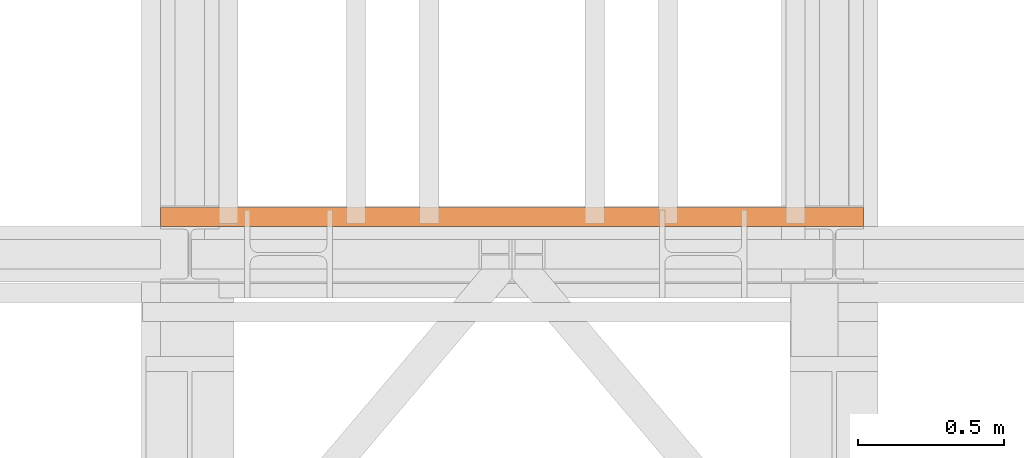
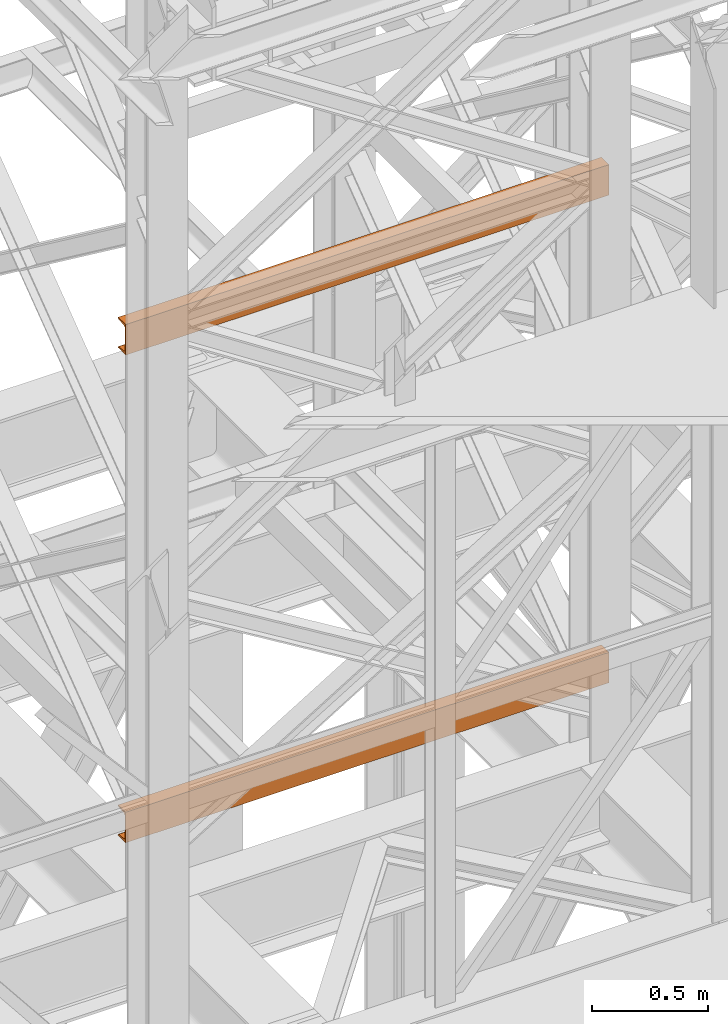
# One storey, part 149 of 208: 2 proxies.
"""IFC2X3 building model written with IfcOpenShell, lengths in millimetres."""

from ifc_helpers import new_model, entity, si_unit, converted_unit, frame, origin, origin_with_axes, place, context, subcontext, project, spatial, faceted_brep, element, save


model = new_model("IFC2X3")

# Units and contexts
model_context = context("Model", 3, precision=1e-05, world=origin())
plan_context = context("Plan", 3, precision=1e-05, world=origin())
body_context = subcontext(model_context, "Body", "Model", "MODEL_VIEW")
ifc_project = project(units=[si_unit("LENGTHUNIT", "METRE", prefix="MILLI"), converted_unit("PLANEANGLEUNIT", "DEGREE", entity("IfcPlaneAngleMeasure", 0.0174532925199433), si_unit("PLANEANGLEUNIT", "RADIAN"), dimensions=[0, 0, 0, 0, 0, 0, 0]), si_unit("AREAUNIT", "SQUARE_METRE"), si_unit("VOLUMEUNIT", "CUBIC_METRE")], contexts=[model_context, plan_context])

# Building, storey
building_placement = place(None, origin())
building = spatial("IfcBuilding", under=ifc_project, at=building_placement, CompositionType="COMPLEX")
storey_placement = place(building_placement, origin_with_axes())
storey = spatial("IfcBuildingStorey", under=building, at=storey_placement, Name="Geschoss", CompositionType="ELEMENT")

# Proxies
proxy_1_placement = place(storey_placement, frame((3193.302372304859, -15867.5743840594, 5524.960005364417), z_axis=(0.0, 0.0, 1.0), x_axis=(1.0, 0.0, 0.0)))
element("IfcBuildingElementProxy", 1, at=proxy_1_placement, inside=storey, context=body_context, shape_type="Brep", body=[
    faceted_brep([(2399.962597713924, 0.01853275732537441, 160.0100000000002), (0.009999999999308784, 0.00999999999839929, 160.0100000000002), (0.009999999999308784, 65.0099999999984, 160.0100000000002), (2399.962597713924, 65.01853275732537, 160.0100000000002), (2399.962597713924, 65.01853275732537, 160.0100000000002), (0.009999999999308784, 65.0099999999984, 160.0100000000002), (0.009999999999308784, 65.0099999999984, 156.8875719297539), (2399.962597713924, 65.01853275732537, 156.8875719297539), (2399.962597713924, 65.01853275732537, 156.8875719297539), (0.009999999999308784, 65.0099999999984, 156.8875719297539), (0.009999999999308784, 64.76726342282564, 155.2717110918293), (2399.962597713924, 64.77579618015261, 155.2717110918293), (2399.962597713924, 64.77579618015261, 155.2717110918293), (0.009999999999308784, 64.76726342282564, 155.2717110918293), (0.009999999999308784, 64.06053228585733, 153.7984655565542), (2399.962597713924, 64.06906504318067, 153.7984655565542), (2399.962597713924, 64.06906504318067, 153.7984655565542), (0.009999999999308784, 64.06053228585733, 153.7984655565542), (0.009999999999308784, 62.9521516384666, 152.5978732961266), (2399.962597713924, 62.96068439579358, 152.5978732961266), (2399.962597713924, 62.96068439579358, 152.5978732961266), (0.009999999999308784, 62.9521516384666, 152.5978732961266), (0.009999999999308784, 61.5399564114814, 151.7759086082897), (2399.962597713924, 61.54848916880837, 151.7759086082897), (2399.962597713924, 61.54848916880837, 151.7759086082897), (0.009999999999308784, 61.5399564114814, 151.7759086082897), (0.009999999999308784, 59.94859872255256, 151.4050878978051), (2399.962597713924, 59.95713147987954, 151.4050878978051), (2399.962597713924, 59.95713147987954, 151.4050878978051), (0.009999999999308784, 59.94859872255256, 151.4050878978051), (0.009999999999308784, 17.17267516602806, 147.9830140132835), (2399.962597713924, 17.18120792335503, 147.9830140132835), (2399.962597713924, 17.18120792335503, 147.9830140132835), (0.009999999999308784, 17.17267516602806, 147.9830140132835), (0.009999999999308784, 14.20840820800731, 147.318026761528), (2399.962597713924, 14.21694096533429, 147.318026761528), (2399.962597713924, 14.21694096533429, 147.318026761528), (0.009999999999308784, 14.20840820800731, 147.318026761528), (0.009999999999308784, 11.43861959928836, 145.7058782528511), (2399.962597713924, 11.4471523566117, 145.7058782528511), (2399.962597713924, 11.4471523566117, 145.7058782528511), (0.009999999999308784, 11.43861959928836, 145.7058782528511), (0.009999999999308784, 9.322620181545062, 143.4138384829421), (2399.962597713924, 9.331152938872037, 143.4138384829421), (2399.962597713924, 9.331152938872037, 143.4138384829421), (0.009999999999308784, 9.322620181545062, 143.4138384829421), (0.009999999999308784, 7.973406192784751, 140.6012788246917), (2399.962597713924, 7.981938950111726, 140.6012788246917), (2399.962597713924, 7.981938950111726, 140.6012788246917), (0.009999999999308784, 7.973406192784751, 140.6012788246917), (0.009999999999308784, 7.509999999998399, 137.5164535886543), (2399.962597713924, 7.518532757325374, 137.5164535886543), (2399.962597713924, 7.518532757325374, 137.5164535886543), (0.009999999999308784, 7.509999999998399, 137.5164535886543), (0.009999999999308784, 7.509999999998399, 22.503546411348), (2399.962597713924, 7.518532757325374, 22.503546411348), (2399.962597713924, 7.518532757325374, 22.503546411348), (0.009999999999308784, 7.509999999998399, 22.503546411348), (0.009999999999308784, 7.973406192784751, 19.41872117530875), (2399.962597713924, 7.981938950111726, 19.41872117530875), (2399.962597713924, 7.981938950111726, 19.41872117530875), (0.009999999999308784, 7.973406192784751, 19.41872117530875), (0.009999999999308784, 9.322620181545062, 16.60616151705835), (2399.962597713924, 9.331152938872037, 16.60616151705835), (2399.962597713924, 9.331152938872037, 16.60616151705835), (0.009999999999308784, 9.322620181545062, 16.60616151705835), (0.009999999999308784, 11.43861959928836, 14.31412174714933), (2399.962597713924, 11.4471523566117, 14.31412174714933), (2399.962597713924, 11.4471523566117, 14.31412174714933), (0.009999999999308784, 11.43861959928836, 14.31412174714933), (0.009999999999308784, 14.13462866898408, 12.74491643400688), (2399.962597713924, 14.14316142630742, 12.74491643400688), (2399.962597713924, 14.14316142630742, 12.74491643400688), (0.009999999999308784, 14.13462866898408, 12.74491643400688), (0.009999999999308784, 17.17267516602806, 12.03698598671872), (2399.962597713924, 17.18120792335503, 12.03698598671872), (2399.962597713924, 17.18120792335503, 12.03698598671872), (0.009999999999308784, 17.17267516602806, 12.03698598671872), (0.009999999999308784, 59.94859872255256, 8.614912102195376), (2399.962597713924, 59.95713147987954, 8.614912102195376), (2399.962597713924, 59.95713147987954, 8.614912102195376), (0.009999999999308784, 59.94859872255256, 8.614912102195376), (0.009999999999308784, 61.5399564114814, 8.244091391710754), (2399.962597713924, 61.54848916880837, 8.244091391710754), (2399.962597713924, 61.54848916880837, 8.244091391710754), (0.009999999999308784, 61.5399564114814, 8.244091391710754), (0.009999999999308784, 62.9521516384666, 7.422126703873801), (2399.962597713924, 62.96068439579358, 7.422126703873801), (2399.962597713924, 62.96068439579358, 7.422126703873801), (0.009999999999308784, 62.9521516384666, 7.422126703873801), (0.009999999999308784, 64.06053228585733, 6.221534443446217), (2399.962597713924, 64.06906504318067, 6.221534443446217), (2399.962597713924, 64.06906504318067, 6.221534443446217), (0.009999999999308784, 64.06053228585733, 6.221534443446217), (0.009999999999308784, 64.76726342282564, 4.748288908172981), (2399.962597713924, 64.77579618015261, 4.748288908172981), (2399.962597713924, 64.77579618015261, 4.748288908172981), (0.009999999999308784, 64.76726342282564, 4.748288908172981), (0.009999999999308784, 65.0099999999984, 0.01000000000021828), (2399.962597713924, 65.01853275732537, 0.01000000000021828), (2399.962597713924, 65.01853275732537, 0.01000000000021828), (0.009999999999308784, 65.0099999999984, 0.01000000000021828), (0.009999999999308784, 0.00999999999839929, 0.01000000000021828), (2399.962597713924, 0.01853275732537441, 0.01000000000021828), (2399.962597713924, 0.01853275732537441, 0.01000000000021828), (0.009999999999308784, 0.00999999999839929, 0.01000000000021828), (0.009999999999308784, 0.00999999999839929, 160.0100000000002), (2399.962597713924, 0.01853275732537441, 160.0100000000002), (2399.962597713924, 0.01853275732537441, 160.0100000000002), (2399.962597713924, 65.01853275732537, 160.0100000000002), (2399.962597713924, 65.01853275732537, 156.8875719297539), (2399.962597713924, 64.77579618015261, 155.2717110918293), (2399.962597713924, 64.06906504318067, 153.7984655565542), (2399.962597713924, 62.96068439579358, 152.5978732961266), (2399.962597713924, 61.54848916880837, 151.7759086082897), (2399.962597713924, 59.95713147987954, 151.4050878978051), (2399.962597713924, 17.18120792335503, 147.9830140132835), (2399.962597713924, 14.21694096533429, 147.318026761528), (2399.962597713924, 11.4471523566117, 145.7058782528511), (2399.962597713924, 9.331152938872037, 143.4138384829421), (2399.962597713924, 7.981938950111726, 140.6012788246917), (2399.962597713924, 7.518532757325374, 137.5164535886543), (2399.962597713924, 7.518532757325374, 22.503546411348), (2399.962597713924, 7.981938950111726, 19.41872117530875), (2399.962597713924, 9.331152938872037, 16.60616151705835), (2399.962597713924, 11.4471523566117, 14.31412174714933), (2399.962597713924, 14.14316142630742, 12.74491643400688), (2399.962597713924, 17.18120792335503, 12.03698598671872), (2399.962597713924, 59.95713147987954, 8.614912102195376), (2399.962597713924, 61.54848916880837, 8.244091391710754), (2399.962597713924, 62.96068439579358, 7.422126703873801), (2399.962597713924, 64.06906504318067, 6.221534443446217), (2399.962597713924, 64.77579618015261, 4.748288908172981), (2399.962597713924, 65.01853275732537, 0.01000000000021828), (2399.962597713924, 0.01853275732537441, 0.01000000000021828), (0.009999999999308784, 0.00999999999839929, 160.0100000000002), (0.009999999999308784, 0.00999999999839929, 0.01000000000021828), (0.009999999999308784, 65.0099999999984, 0.01000000000021828), (0.009999999999308784, 64.76726342282564, 4.748288908172981), (0.009999999999308784, 64.06053228585733, 6.221534443446217), (0.009999999999308784, 62.9521516384666, 7.422126703873801), (0.009999999999308784, 61.5399564114814, 8.244091391710754), (0.009999999999308784, 59.94859872255256, 8.614912102195376), (0.009999999999308784, 17.17267516602806, 12.03698598671872), (0.009999999999308784, 14.13462866898408, 12.74491643400688), (0.009999999999308784, 11.43861959928836, 14.31412174714933), (0.009999999999308784, 9.322620181545062, 16.60616151705835), (0.009999999999308784, 7.973406192784751, 19.41872117530875), (0.009999999999308784, 7.509999999998399, 22.503546411348), (0.009999999999308784, 7.509999999998399, 137.5164535886543), (0.009999999999308784, 7.973406192784751, 140.6012788246917), (0.009999999999308784, 9.322620181545062, 143.4138384829421), (0.009999999999308784, 11.43861959928836, 145.7058782528511), (0.009999999999308784, 14.20840820800731, 147.318026761528), (0.009999999999308784, 17.17267516602806, 147.9830140132835), (0.009999999999308784, 59.94859872255256, 151.4050878978051), (0.009999999999308784, 61.5399564114814, 151.7759086082897), (0.009999999999308784, 62.9521516384666, 152.5978732961266), (0.009999999999308784, 64.06053228585733, 153.7984655565542), (0.009999999999308784, 64.76726342282564, 155.2717110918293), (0.009999999999308784, 65.0099999999984, 156.8875719297539), (0.009999999999308784, 65.0099999999984, 160.0100000000002)], [[[0, 1, 2, 3]], [[4, 5, 6, 7]], [[8, 9, 10, 11]], [[12, 13, 14, 15]], [[16, 17, 18, 19]], [[20, 21, 22, 23]], [[24, 25, 26, 27]], [[28, 29, 30, 31]], [[32, 33, 34, 35]], [[36, 37, 38, 39]], [[40, 41, 42, 43]], [[44, 45, 46, 47]], [[48, 49, 50, 51]], [[52, 53, 54, 55]], [[56, 57, 58, 59]], [[60, 61, 62, 63]], [[64, 65, 66, 67]], [[68, 69, 70, 71]], [[72, 73, 74, 75]], [[76, 77, 78, 79]], [[80, 81, 82, 83]], [[84, 85, 86, 87]], [[88, 89, 90, 91]], [[92, 93, 94, 95]], [[96, 97, 98, 99]], [[100, 101, 102, 103]], [[104, 105, 106, 107]], [[108, 109, 110, 111, 112, 113, 114, 115, 116, 117, 118, 119, 120, 121, 122, 123, 124, 125, 126, 127, 128, 129, 130, 131, 132, 133, 134]], [[135, 136, 137, 138, 139, 140, 141, 142, 143, 144, 145, 146, 147, 148, 149, 150, 151, 152, 153, 154, 155, 156, 157, 158, 159, 160, 161]]], orient=[[False], [False], [False], [False], [False], [False], [False], [False], [False], [False], [False], [False], [False], [False], [False], [False], [False], [False], [False], [False], [False], [False], [False], [False], [False], [False], [False], [False], [False]]),
])
proxy_2_placement = place(storey_placement, frame((3193.302372304859, -15867.5743840594, 8084.960005364417), z_axis=(0.0, 0.0, 1.0), x_axis=(1.0, 0.0, 0.0)))
element("IfcBuildingElementProxy", 2, at=proxy_2_placement, inside=storey, context=body_context, shape_type="Brep", body=[
    faceted_brep([(2399.962597713924, 0.01853275732537441, 160.0100000000002), (0.009999999999308784, 0.00999999999839929, 160.0100000000002), (0.009999999999308784, 65.0099999999984, 160.0100000000002), (2399.962597713924, 65.01853275732537, 160.0100000000002), (2399.962597713924, 65.01853275732537, 160.0100000000002), (0.009999999999308784, 65.0099999999984, 160.0100000000002), (0.009999999999308784, 65.0099999999984, 156.8875719297539), (2399.962597713924, 65.01853275732537, 156.8875719297539), (2399.962597713924, 65.01853275732537, 156.8875719297539), (0.009999999999308784, 65.0099999999984, 156.8875719297539), (0.009999999999308784, 64.76726342282564, 155.2717110918293), (2399.962597713924, 64.77579618015261, 155.2717110918293), (2399.962597713924, 64.77579618015261, 155.2717110918293), (0.009999999999308784, 64.76726342282564, 155.2717110918293), (0.009999999999308784, 64.06053228585733, 153.7984655565542), (2399.962597713924, 64.06906504318067, 153.7984655565542), (2399.962597713924, 64.06906504318067, 153.7984655565542), (0.009999999999308784, 64.06053228585733, 153.7984655565542), (0.009999999999308784, 62.9521516384666, 152.5978732961266), (2399.962597713924, 62.96068439579358, 152.5978732961266), (2399.962597713924, 62.96068439579358, 152.5978732961266), (0.009999999999308784, 62.9521516384666, 152.5978732961266), (0.009999999999308784, 61.5399564114814, 151.7759086082897), (2399.962597713924, 61.54848916880837, 151.7759086082897), (2399.962597713924, 61.54848916880837, 151.7759086082897), (0.009999999999308784, 61.5399564114814, 151.7759086082897), (0.009999999999308784, 59.94859872255256, 151.4050878978051), (2399.962597713924, 59.95713147987954, 151.4050878978051), (2399.962597713924, 59.95713147987954, 151.4050878978051), (0.009999999999308784, 59.94859872255256, 151.4050878978051), (0.009999999999308784, 17.17267516602806, 147.9830140132835), (2399.962597713924, 17.18120792335503, 147.9830140132835), (2399.962597713924, 17.18120792335503, 147.9830140132835), (0.009999999999308784, 17.17267516602806, 147.9830140132835), (0.009999999999308784, 14.20840820800731, 147.318026761528), (2399.962597713924, 14.21694096533429, 147.318026761528), (2399.962597713924, 14.21694096533429, 147.318026761528), (0.009999999999308784, 14.20840820800731, 147.318026761528), (0.009999999999308784, 11.43861959928836, 145.7058782528511), (2399.962597713924, 11.4471523566117, 145.7058782528511), (2399.962597713924, 11.4471523566117, 145.7058782528511), (0.009999999999308784, 11.43861959928836, 145.7058782528511), (0.009999999999308784, 9.322620181545062, 143.4138384829421), (2399.962597713924, 9.331152938872037, 143.4138384829421), (2399.962597713924, 9.331152938872037, 143.4138384829421), (0.009999999999308784, 9.322620181545062, 143.4138384829421), (0.009999999999308784, 7.973406192784751, 140.6012788246917), (2399.962597713924, 7.981938950111726, 140.6012788246917), (2399.962597713924, 7.981938950111726, 140.6012788246917), (0.009999999999308784, 7.973406192784751, 140.6012788246917), (0.009999999999308784, 7.509999999998399, 137.5164535886543), (2399.962597713924, 7.518532757325374, 137.5164535886543), (2399.962597713924, 7.518532757325374, 137.5164535886543), (0.009999999999308784, 7.509999999998399, 137.5164535886543), (0.009999999999308784, 7.509999999998399, 22.503546411348), (2399.962597713924, 7.518532757325374, 22.503546411348), (2399.962597713924, 7.518532757325374, 22.503546411348), (0.009999999999308784, 7.509999999998399, 22.503546411348), (0.009999999999308784, 7.973406192784751, 19.41872117530875), (2399.962597713924, 7.981938950111726, 19.41872117530875), (2399.962597713924, 7.981938950111726, 19.41872117530875), (0.009999999999308784, 7.973406192784751, 19.41872117530875), (0.009999999999308784, 9.322620181545062, 16.60616151705835), (2399.962597713924, 9.331152938872037, 16.60616151705835), (2399.962597713924, 9.331152938872037, 16.60616151705835), (0.009999999999308784, 9.322620181545062, 16.60616151705835), (0.009999999999308784, 11.43861959928836, 14.31412174714933), (2399.962597713924, 11.4471523566117, 14.31412174714933), (2399.962597713924, 11.4471523566117, 14.31412174714933), (0.009999999999308784, 11.43861959928836, 14.31412174714933), (0.009999999999308784, 14.13462866898408, 12.74491643400688), (2399.962597713924, 14.14316142630742, 12.74491643400688), (2399.962597713924, 14.14316142630742, 12.74491643400688), (0.009999999999308784, 14.13462866898408, 12.74491643400688), (0.009999999999308784, 17.17267516602806, 12.03698598671872), (2399.962597713924, 17.18120792335503, 12.03698598671872), (2399.962597713924, 17.18120792335503, 12.03698598671872), (0.009999999999308784, 17.17267516602806, 12.03698598671872), (0.009999999999308784, 59.94859872255256, 8.614912102195376), (2399.962597713924, 59.95713147987954, 8.614912102195376), (2399.962597713924, 59.95713147987954, 8.614912102195376), (0.009999999999308784, 59.94859872255256, 8.614912102195376), (0.009999999999308784, 61.5399564114814, 8.244091391710754), (2399.962597713924, 61.54848916880837, 8.244091391710754), (2399.962597713924, 61.54848916880837, 8.244091391710754), (0.009999999999308784, 61.5399564114814, 8.244091391710754), (0.009999999999308784, 62.9521516384666, 7.422126703873801), (2399.962597713924, 62.96068439579358, 7.422126703873801), (2399.962597713924, 62.96068439579358, 7.422126703873801), (0.009999999999308784, 62.9521516384666, 7.422126703873801), (0.009999999999308784, 64.06053228585733, 6.221534443446217), (2399.962597713924, 64.06906504318067, 6.221534443446217), (2399.962597713924, 64.06906504318067, 6.221534443446217), (0.009999999999308784, 64.06053228585733, 6.221534443446217), (0.009999999999308784, 64.76726342282564, 4.748288908172981), (2399.962597713924, 64.77579618015261, 4.748288908172981), (2399.962597713924, 64.77579618015261, 4.748288908172981), (0.009999999999308784, 64.76726342282564, 4.748288908172981), (0.009999999999308784, 65.0099999999984, 0.01000000000021828), (2399.962597713924, 65.01853275732537, 0.01000000000021828), (2399.962597713924, 65.01853275732537, 0.01000000000021828), (0.009999999999308784, 65.0099999999984, 0.01000000000021828), (0.009999999999308784, 0.00999999999839929, 0.01000000000021828), (2399.962597713924, 0.01853275732537441, 0.01000000000021828), (2399.962597713924, 0.01853275732537441, 0.01000000000021828), (0.009999999999308784, 0.00999999999839929, 0.01000000000021828), (0.009999999999308784, 0.00999999999839929, 160.0100000000002), (2399.962597713924, 0.01853275732537441, 160.0100000000002), (2399.962597713924, 0.01853275732537441, 160.0100000000002), (2399.962597713924, 65.01853275732537, 160.0100000000002), (2399.962597713924, 65.01853275732537, 156.8875719297539), (2399.962597713924, 64.77579618015261, 155.2717110918293), (2399.962597713924, 64.06906504318067, 153.7984655565542), (2399.962597713924, 62.96068439579358, 152.5978732961266), (2399.962597713924, 61.54848916880837, 151.7759086082897), (2399.962597713924, 59.95713147987954, 151.4050878978051), (2399.962597713924, 17.18120792335503, 147.9830140132835), (2399.962597713924, 14.21694096533429, 147.318026761528), (2399.962597713924, 11.4471523566117, 145.7058782528511), (2399.962597713924, 9.331152938872037, 143.4138384829421), (2399.962597713924, 7.981938950111726, 140.6012788246917), (2399.962597713924, 7.518532757325374, 137.5164535886543), (2399.962597713924, 7.518532757325374, 22.503546411348), (2399.962597713924, 7.981938950111726, 19.41872117530875), (2399.962597713924, 9.331152938872037, 16.60616151705835), (2399.962597713924, 11.4471523566117, 14.31412174714933), (2399.962597713924, 14.14316142630742, 12.74491643400688), (2399.962597713924, 17.18120792335503, 12.03698598671872), (2399.962597713924, 59.95713147987954, 8.614912102195376), (2399.962597713924, 61.54848916880837, 8.244091391710754), (2399.962597713924, 62.96068439579358, 7.422126703873801), (2399.962597713924, 64.06906504318067, 6.221534443446217), (2399.962597713924, 64.77579618015261, 4.748288908172981), (2399.962597713924, 65.01853275732537, 0.01000000000021828), (2399.962597713924, 0.01853275732537441, 0.01000000000021828), (0.009999999999308784, 0.00999999999839929, 160.0100000000002), (0.009999999999308784, 0.00999999999839929, 0.01000000000021828), (0.009999999999308784, 65.0099999999984, 0.01000000000021828), (0.009999999999308784, 64.76726342282564, 4.748288908172981), (0.009999999999308784, 64.06053228585733, 6.221534443446217), (0.009999999999308784, 62.9521516384666, 7.422126703873801), (0.009999999999308784, 61.5399564114814, 8.244091391710754), (0.009999999999308784, 59.94859872255256, 8.614912102195376), (0.009999999999308784, 17.17267516602806, 12.03698598671872), (0.009999999999308784, 14.13462866898408, 12.74491643400688), (0.009999999999308784, 11.43861959928836, 14.31412174714933), (0.009999999999308784, 9.322620181545062, 16.60616151705835), (0.009999999999308784, 7.973406192784751, 19.41872117530875), (0.009999999999308784, 7.509999999998399, 22.503546411348), (0.009999999999308784, 7.509999999998399, 137.5164535886543), (0.009999999999308784, 7.973406192784751, 140.6012788246917), (0.009999999999308784, 9.322620181545062, 143.4138384829421), (0.009999999999308784, 11.43861959928836, 145.7058782528511), (0.009999999999308784, 14.20840820800731, 147.318026761528), (0.009999999999308784, 17.17267516602806, 147.9830140132835), (0.009999999999308784, 59.94859872255256, 151.4050878978051), (0.009999999999308784, 61.5399564114814, 151.7759086082897), (0.009999999999308784, 62.9521516384666, 152.5978732961266), (0.009999999999308784, 64.06053228585733, 153.7984655565542), (0.009999999999308784, 64.76726342282564, 155.2717110918293), (0.009999999999308784, 65.0099999999984, 156.8875719297539), (0.009999999999308784, 65.0099999999984, 160.0100000000002)], [[[0, 1, 2, 3]], [[4, 5, 6, 7]], [[8, 9, 10, 11]], [[12, 13, 14, 15]], [[16, 17, 18, 19]], [[20, 21, 22, 23]], [[24, 25, 26, 27]], [[28, 29, 30, 31]], [[32, 33, 34, 35]], [[36, 37, 38, 39]], [[40, 41, 42, 43]], [[44, 45, 46, 47]], [[48, 49, 50, 51]], [[52, 53, 54, 55]], [[56, 57, 58, 59]], [[60, 61, 62, 63]], [[64, 65, 66, 67]], [[68, 69, 70, 71]], [[72, 73, 74, 75]], [[76, 77, 78, 79]], [[80, 81, 82, 83]], [[84, 85, 86, 87]], [[88, 89, 90, 91]], [[92, 93, 94, 95]], [[96, 97, 98, 99]], [[100, 101, 102, 103]], [[104, 105, 106, 107]], [[108, 109, 110, 111, 112, 113, 114, 115, 116, 117, 118, 119, 120, 121, 122, 123, 124, 125, 126, 127, 128, 129, 130, 131, 132, 133, 134]], [[135, 136, 137, 138, 139, 140, 141, 142, 143, 144, 145, 146, 147, 148, 149, 150, 151, 152, 153, 154, 155, 156, 157, 158, 159, 160, 161]]], orient=[[False], [False], [False], [False], [False], [False], [False], [False], [False], [False], [False], [False], [False], [False], [False], [False], [False], [False], [False], [False], [False], [False], [False], [False], [False], [False], [False], [False], [False]]),
])

save(model, "model.ifc")
